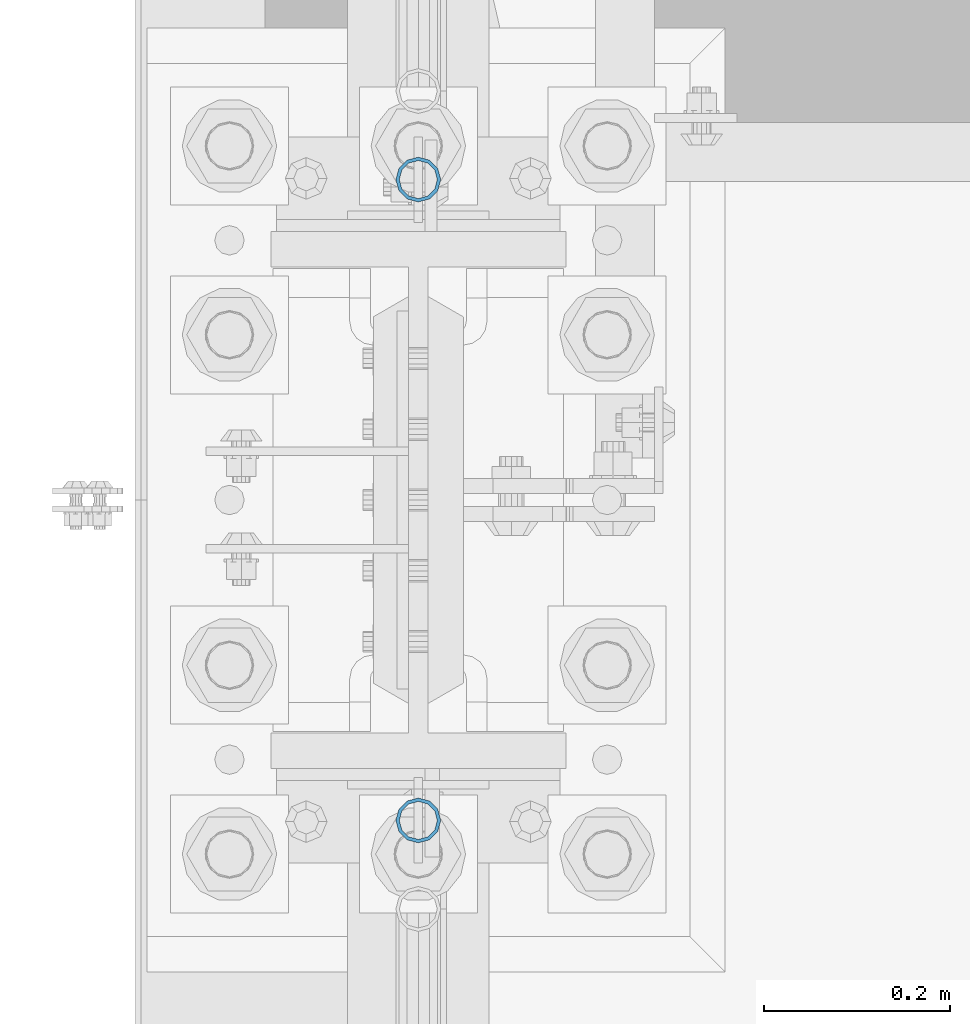
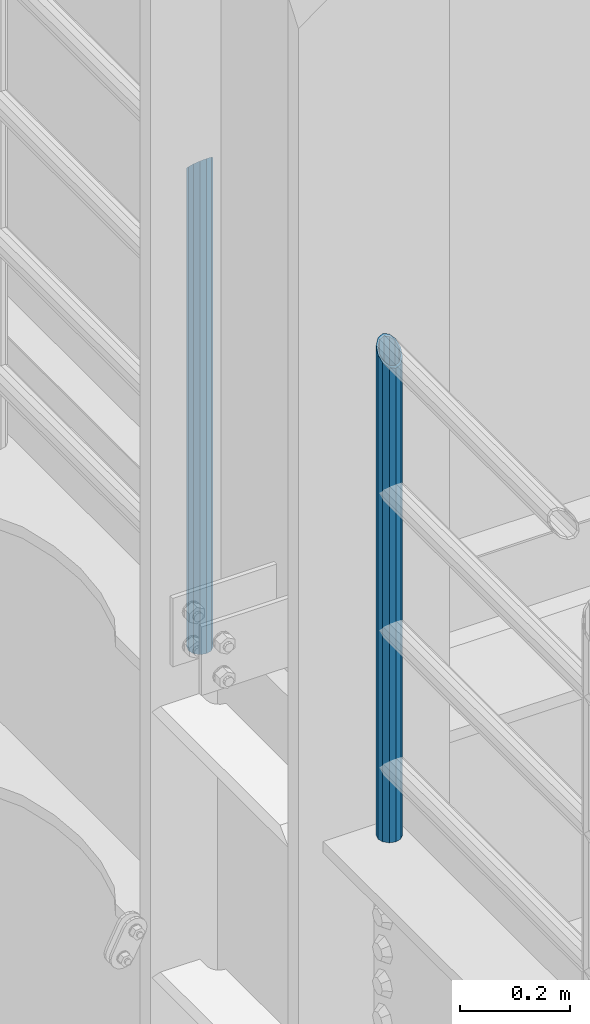
# One storey, part 685 of 1876: 2 columns, 2 elements without a shape of their own.
"""IFC2X3 building model written with IfcOpenShell, lengths in millimetres."""

import ifcopenshell
import ifcopenshell.guid

model = None  # the IFC model being written
_history = None  # IfcOwnerHistory: only IFC2X3 demands one
_inside = {}  # id of a spatial element -> (the spatial element, [elements in it])
_under = {}  # id of a project, library or spatial element -> (it, [spatial elements below it])
_declared = {}  # id of a project -> (the project, [libraries it declares])
_typed = {}  # id of a type object -> (the type object, [elements of that type])
_made_of = {}  # id of a material, layer set ... -> (it, [elements and type objects made of it])


def new_model(schema):
    """Start an empty IFC model of exactly this schema.

    Asked for "IFC4X3", IfcOpenShell would pick the latest addendum, in which some entities
    have other attributes; the version numbers below select the first issue.
    IFC2X3 requires an IfcOwnerHistory on every rooted entity: one is made here for all.
    """
    global model, _history
    if schema == "IFC4X3":
        model = ifcopenshell.file(schema_version=(4, 3, 0, 0))
    else:
        model = ifcopenshell.file(schema=schema)
    _inside.clear()
    _under.clear()
    _declared.clear()
    _typed.clear()
    _made_of.clear()
    _history = None
    if model.schema == "IFC2X3":
        org = make("IfcOrganization", Name="unknown")
        user = make(
            "IfcPersonAndOrganization",
            ThePerson=make("IfcPerson", FamilyName="unknown"),
            TheOrganization=org,
        )
        app = make(
            "IfcApplication",
            ApplicationDeveloper=org,
            Version="unknown",
            ApplicationFullName="unknown",
            ApplicationIdentifier="unknown",
        )
        _history = make(
            "IfcOwnerHistory",
            OwningUser=user,
            OwningApplication=app,
            ChangeAction="ADDED",
            CreationDate=0,
        )
    return model


def make(cls, **values):
    """One entity of the class cls with the attributes given. An attribute that is None is left unset."""
    return model.create_entity(
        cls, **{name: value for name, value in values.items() if value is not None}
    )


def rooted(cls, **values):
    """An entity with a GlobalId (a new one), such as an element, a storey or a relation."""
    return make(cls, GlobalId=ifcopenshell.guid.new(), OwnerHistory=_history, **values)


def si_unit(unit_type, name, prefix=None):
    """IfcSIUnit, for example si_unit("LENGTHUNIT", "METRE", prefix="MILLI")."""
    return make("IfcSIUnit", UnitType=unit_type, Prefix=prefix, Name=name)


def assignment(units):
    """IfcUnitAssignment: the units of a project."""
    return None if units is None else make("IfcUnitAssignment", Units=units)


def point(xyz):
    """IfcCartesianPoint."""
    return None if xyz is None else make("IfcCartesianPoint", Coordinates=xyz)


def direction(xyz):
    """IfcDirection."""
    return None if xyz is None else make("IfcDirection", DirectionRatios=xyz)


def frame(location, z_axis=None, x_axis=None):
    """IfcAxis2Placement3D, a coordinate frame: its origin and axes. An axis left out is left unset."""
    return make(
        "IfcAxis2Placement3D",
        Location=point(location),
        Axis=direction(z_axis),
        RefDirection=direction(x_axis),
    )


def origin_with_axes():
    """The frame at (0, 0, 0) with the z axis (0, 0, 1) and the x axis (1, 0, 0) written out."""
    return frame((0.0, 0.0, 0.0), z_axis=(0.0, 0.0, 1.0), x_axis=(1.0, 0.0, 0.0))


def place(relative_to, where):
    """IfcLocalPlacement: puts the frame where relative to a parent placement (None: the world)."""
    return make(
        "IfcLocalPlacement", PlacementRelTo=relative_to, RelativePlacement=where
    )


def context(
    kind, dimensions, precision=None, world=None, true_north=None, identifier=None
):
    """IfcGeometricRepresentationContext, for example the 3D "Model" context."""
    return make(
        "IfcGeometricRepresentationContext",
        ContextIdentifier=identifier,
        ContextType=kind,
        CoordinateSpaceDimension=dimensions,
        Precision=precision,
        WorldCoordinateSystem=world,
        TrueNorth=true_north,
    )


def subcontext(parent, identifier, kind, view, scale=None):
    """IfcGeometricRepresentationSubContext, for example "Body" below "Model"."""
    return make(
        "IfcGeometricRepresentationSubContext",
        ContextIdentifier=identifier,
        ContextType=kind,
        ParentContext=parent,
        TargetScale=scale,
        TargetView=view,
    )


def project(units=None, contexts=None):
    """IfcProject with its units and contexts."""
    return rooted(
        "IfcProject",
        Name="project",
        RepresentationContexts=contexts,
        UnitsInContext=assignment(units),
    )


def spatial(cls, under=None, at=None, **own):
    """A site, building, storey or space (cls), placed at a placement, below another one or the project."""
    s = rooted(cls, ObjectPlacement=at, **own)
    if under is not None:
        _under.setdefault(under.id(), (under, []))[1].append(s)
    return s


def faces_of(points, faces, orient=None, outer=None):
    """IfcFace entities. A face is a list of loops; a loop is a list of indices into points, from 0.

    orient and outer hold one flag for each loop. By default every Orientation is true, the
    first loop of a face is its IfcFaceOuterBound and the others are IfcFaceBound.
    """
    made = []
    for i, loops in enumerate(faces):
        bounds = []
        for j, loop in enumerate(loops):
            is_outer = j == 0 if outer is None else outer[i][j]
            bounds.append(
                make(
                    "IfcFaceOuterBound" if is_outer else "IfcFaceBound",
                    Bound=make("IfcPolyLoop", Polygon=[points[k] for k in loop]),
                    Orientation=True if orient is None else orient[i][j],
                )
            )
        made.append(make("IfcFace", Bounds=bounds))
    return made


def faceted_brep(points, faces, orient=None, outer=None, voids=None):
    """IfcFacetedBrep: a solid bounded by flat faces; with voids (closed shells), ...WithVoids."""
    shared = [point(p) for p in points]
    hull = make("IfcClosedShell", CfsFaces=faces_of(shared, faces, orient, outer))
    if voids is None:
        return make("IfcFacetedBrep", Outer=hull)
    return make(
        "IfcFacetedBrepWithVoids",
        Outer=hull,
        Voids=[
            make(cls, CfsFaces=faces_of(shared, fs, o, b)) for cls, fs, o, b in voids
        ],
    )


def shape(context_of_items, identifier, shape_type, items):
    """IfcShapeRepresentation: the items that make up one representation, for example the "Body"."""
    return make(
        "IfcShapeRepresentation",
        ContextOfItems=context_of_items,
        RepresentationIdentifier=identifier,
        RepresentationType=shape_type,
        Items=items,
    )


def material(Name=None, Category=None):
    """IfcMaterial."""
    return make("IfcMaterial", Name=Name, Category=Category)


def made_of(thing, what):
    """Note that an element or type object is made of a material, layer set ...; save() writes the relation."""
    if what is not None:
        _made_of.setdefault(what.id(), (what, []))[1].append(thing)
    return thing


def type_object(cls, material=None, **own):
    """A type object (cls), such as IfcWallType, which elements share."""
    return made_of(rooted(cls, **own), material)


def element(
    cls,
    number,
    at=None,
    inside=None,
    cuts=None,
    type_object=None,
    material=None,
    context=None,
    identifier="Body",
    shape_type=None,
    held_by="IfcProductDefinitionShape",
    body=None,
    shapes=None,
    **own,
):
    """One element of the class cls, such as IfcWall. Its Tag is "e" and its number.

    at: its placement. inside: the storey or other place that contains it. cuts: it is an
    opening in that element (IfcRelVoidsElement). A single representation is given by context,
    identifier, shape_type and body (its items); several are given by shapes. held_by: the class
    of the entity that holds the representations. save() writes the other relations.
    """
    e = rooted(cls, Tag="e%d" % number, ObjectPlacement=at, **own)
    if body is not None:
        shapes = [shape(context, identifier, shape_type, body)]
    if shapes is not None:
        e.Representation = make(held_by, Representations=shapes)
    if inside is not None:
        _inside.setdefault(inside.id(), (inside, []))[1].append(e)
    if cuts is not None:
        rooted(
            "IfcRelVoidsElement", RelatingBuildingElement=cuts, RelatedOpeningElement=e
        )
    if type_object is not None:
        _typed.setdefault(type_object.id(), (type_object, []))[1].append(e)
    return made_of(e, material)


def aggregate(whole, parts):
    """IfcRelAggregates: a whole, such as a stair, and the parts it consists of."""
    return rooted("IfcRelAggregates", RelatingObject=whole, RelatedObjects=parts)


def save(model, path):
    """Write the relations noted so far, then the file.

    IfcRelAggregates (storeys below a building ...), IfcRelContainedInSpatialStructure (elements
    in a storey), IfcRelDefinesByType, IfcRelAssociatesMaterial and IfcRelDeclares: one each for
    every whole, place, type object, material and project.
    """
    for whole, parts in _under.values():
        aggregate(whole, parts)
    for where, things in _inside.values():
        rooted(
            "IfcRelContainedInSpatialStructure",
            RelatedElements=things,
            RelatingStructure=where,
        )
    for kind, things in _typed.values():
        rooted("IfcRelDefinesByType", RelatedObjects=things, RelatingType=kind)
    for what, things in _made_of.values():
        rooted("IfcRelAssociatesMaterial", RelatedObjects=things, RelatingMaterial=what)
    for by, libraries in _declared.values():
        rooted("IfcRelDeclares", RelatingContext=by, RelatedDefinitions=libraries)
    model.write(path)


model = new_model("IFC2X3")

# Units and contexts
model_context = context("Model", 3, precision=1e-05, world=origin_with_axes())
body_context = subcontext(model_context, "Body", "Model", "MODEL_VIEW")
ifc_project = project(units=[si_unit("LENGTHUNIT", "METRE", prefix="MILLI"), si_unit("AREAUNIT", "SQUARE_METRE"), si_unit("VOLUMEUNIT", "CUBIC_METRE"), si_unit("MASSUNIT", "GRAM", prefix="KILO"), si_unit("TIMEUNIT", "SECOND"), si_unit("PLANEANGLEUNIT", "RADIAN"), si_unit("SOLIDANGLEUNIT", "STERADIAN"), si_unit("THERMODYNAMICTEMPERATUREUNIT", "DEGREE_CELSIUS"), si_unit("LUMINOUSINTENSITYUNIT", "LUMEN")], contexts=[model_context])

# Site, building, storey
site_placement = place(None, origin_with_axes())
site = spatial("IfcSite", under=ifc_project, at=site_placement, CompositionType="ELEMENT")
building_placement = place(site_placement, origin_with_axes())
building = spatial("IfcBuilding", under=site, at=building_placement, Name="Undefined", CompositionType="ELEMENT")
storey_placement = place(building_placement, origin_with_axes())
storey = spatial("IfcBuildingStorey", under=building, at=storey_placement, Name="Undefined", CompositionType="ELEMENT", Elevation=0.0)

# Assembly, column
assembly_1_placement = place(storey_placement, origin_with_axes())
assembly_1 = element("IfcElementAssembly", 1, at=assembly_1_placement, inside=storey, Name="RAIL", AssemblyPlace="NOTDEFINED", PredefinedType="RIGID_FRAME")
ifc_material = material()
column_type = type_object("IfcColumnType", Name="PIPE1-1/2SCH40", PredefinedType="NOTDEFINED")
column_1_placement = place(assembly_1_placement, frame((-1.81898940354586e-12, 1179.195, 8153.4), z_axis=(0.0, 1.0, 0.0), x_axis=(0.0, 0.0, 1.0)))
column_1 = element("IfcColumn", 2, at=column_1_placement, type_object=column_type, material=ifc_material, Name="POST", ObjectType="PIPE1-1/2SCH40", context=body_context, shape_type="Brep", body=[
    faceted_brep([(0.0, -20.4469999999999, 0.0), (0.0, -17.7076214311803, 10.2235000000001), (1086.54849999999, -17.7076214311801, 10.2235000000001), (1076.325, -20.4469999999999, 0.0), (0.0, -10.2235000000001, 17.7076214311801), (1094.03262143117, -10.2235000000001, 17.7076214311801), (-1.45519152283669e-11, 0.0, 20.4470000000001), (1096.77199999999, 0.0, 20.4470000000001), (0.0, 10.2235000000001, 17.7076214311801), (1094.03262143117, 10.2235000000001, 17.7076214311801), (0.0, 17.7076214311803, 10.2235000000001), (1086.54849999999, 17.7076214311801, 10.2235000000001), (0.0, 20.4469999999999, 0.0), (1076.325, 20.4469999999999, 0.0), (0.0, 17.7076214311803, -10.2235000000001), (1066.10149999999, 17.7076214311801, -10.2235000000001), (0.0, 10.2235000000001, -17.7076214311801), (1058.61737856881, 10.2235000000001, -17.7076214311801), (-1.45519152283669e-11, 0.0, -20.4470000000001), (1055.87799999999, 0.0, -20.4470000000001), (0.0, -10.2235000000001, -17.7076214311801), (1058.61737856881, -10.2235000000001, -17.7076214311801), (0.0, -17.7076214311803, -10.2235000000001), (1066.10149999999, -17.7076214311801, -10.2235000000001), (0.0, -24.1299999999992, 0.0), (0.0, -20.8971929933184, -12.0649999999996), (1064.25999999999, -20.8971929933186, -12.0649999999996), (1076.325, -24.1300000000001, 0.0), (0.0, -12.0650000000001, -20.8971929933186), (1055.42780700667, -12.0649999999996, -20.8971929933186), (-1.45519152283669e-11, 0.0, -24.130000000001), (1052.19499999999, 0.0, -24.1300000000001), (0.0, 12.0650000000001, -20.8971929933186), (1055.42780700667, 12.0649999999996, -20.8971929933186), (0.0, 20.8971929933184, -12.0649999999996), (1064.25999999999, 20.8971929933186, -12.0649999999996), (0.0, 24.1299999999992, 0.0), (1076.325, 24.1300000000001, 0.0), (0.0, 20.8971929933184, 12.0649999999996), (1088.38999999999, 20.8971929933186, 12.0649999999996), (0.0, 12.0650000000001, 20.8971929933186), (1097.22219299331, 12.0649999999996, 20.8971929933186), (-1.45519152283669e-11, 0.0, 24.130000000001), (1100.45499999999, 0.0, 24.1300000000001), (0.0, -12.0650000000001, 20.8971929933186), (1097.22219299331, -12.0649999999996, 20.8971929933186), (0.0, -20.8971929933184, 12.0649999999996), (1088.38999999999, -20.8971929933186, 12.0649999999996)], [[[0, 1, 2, 3]], [[1, 4, 5, 2]], [[4, 6, 7, 5]], [[6, 8, 9, 7]], [[8, 10, 11, 9]], [[10, 12, 13, 11]], [[12, 14, 15, 13]], [[14, 16, 17, 15]], [[16, 18, 19, 17]], [[18, 20, 21, 19]], [[20, 22, 23, 21]], [[22, 0, 3, 23]], [[24, 25, 26, 27]], [[25, 28, 29, 26]], [[28, 30, 31, 29]], [[30, 32, 33, 31]], [[32, 34, 35, 33]], [[34, 36, 37, 35]], [[36, 38, 39, 37]], [[38, 40, 41, 39]], [[40, 42, 43, 41]], [[42, 44, 45, 43]], [[44, 46, 47, 45]], [[46, 24, 27, 47]], [[29, 31, 33, 35, 37, 39, 41, 43, 45, 47, 27, 26], [5, 7, 9, 11, 13, 15, 17, 19, 21, 23, 3, 2]], [[46, 44, 42, 40, 38, 36, 34, 32, 30, 28, 25, 24], [22, 20, 18, 16, 14, 12, 10, 8, 6, 4, 1, 0]]]),
])
aggregate(assembly_1, [column_1])

assembly_2_placement = place(storey_placement, origin_with_axes())
assembly_2 = element("IfcElementAssembly", 3, at=assembly_2_placement, inside=storey, Name="RAIL", AssemblyPlace="NOTDEFINED", PredefinedType="RIGID_FRAME")
column_2_placement = place(assembly_2_placement, frame((-1.81898940354586e-12, 1868.805, 8153.4), z_axis=(0.0, 1.0, 0.0), x_axis=(0.0, 0.0, 1.0)))
column_2 = element("IfcColumn", 4, at=column_2_placement, type_object=column_type, material=ifc_material, Name="POST", ObjectType="PIPE1-1/2SCH40", context=body_context, shape_type="Brep", body=[
    faceted_brep([(0.0, -20.4469999999999, 0.0), (0.0, -17.7076214311803, 10.2235000000001), (1066.1015, -17.7076214311803, 10.2235000000001), (1076.325, -20.4469999999999, 0.0), (0.0, -10.2235000000001, 17.7076214311801), (1058.61737856882, -10.2235000000001, 17.7076214311801), (-1.45519152283669e-11, 0.0, 20.4470000000001), (1055.878, 0.0, 20.4470000000001), (0.0, 10.2235000000001, 17.7076214311801), (1058.61737856882, 10.2235000000001, 17.7076214311801), (0.0, 17.7076214311803, 10.2235000000001), (1066.1015, 17.7076214311803, 10.2235000000001), (0.0, 20.4469999999999, 0.0), (1076.325, 20.4469999999999, 0.0), (0.0, 17.7076214311803, -10.2235000000001), (1086.5485, 17.7076214311803, -10.2235000000001), (0.0, 10.2235000000001, -17.7076214311801), (1094.03262143118, 10.2235000000001, -17.7076214311801), (-1.45519152283669e-11, 0.0, -20.4470000000001), (1096.772, 0.0, -20.4470000000001), (0.0, -10.2235000000001, -17.7076214311801), (1094.03262143118, -10.2235000000001, -17.7076214311801), (0.0, -17.7076214311803, -10.2235000000001), (1086.5485, -17.7076214311803, -10.2235000000001), (0.0, -24.1299999999992, 0.0), (0.0, -20.8971929933184, -12.0649999999996), (1088.39, -20.8971929933184, -12.0649999999996), (1076.325, -24.1300000000001, 0.0), (0.0, -12.0650000000001, -20.8971929933186), (1097.22219299332, -12.0650000000001, -20.8971929933186), (-1.45519152283669e-11, 0.0, -24.130000000001), (1100.455, 0.0, -24.1300000000001), (0.0, 12.0650000000001, -20.8971929933186), (1097.22219299332, 12.0650000000001, -20.8971929933186), (0.0, 20.8971929933184, -12.0649999999996), (1088.39, 20.8971929933184, -12.0649999999996), (0.0, 24.1299999999992, 0.0), (1076.325, 24.1300000000001, 0.0), (0.0, 20.8971929933184, 12.0649999999996), (1064.26, 20.8971929933184, 12.0649999999996), (0.0, 12.0650000000001, 20.8971929933186), (1055.42780700668, 12.0650000000001, 20.8971929933186), (-1.45519152283669e-11, 0.0, 24.130000000001), (1052.195, 0.0, 24.1300000000001), (0.0, -12.0650000000001, 20.8971929933186), (1055.42780700668, -12.0650000000001, 20.8971929933186), (0.0, -20.8971929933184, 12.0649999999996), (1064.26, -20.8971929933184, 12.0649999999996)], [[[0, 1, 2, 3]], [[1, 4, 5, 2]], [[4, 6, 7, 5]], [[6, 8, 9, 7]], [[8, 10, 11, 9]], [[10, 12, 13, 11]], [[12, 14, 15, 13]], [[14, 16, 17, 15]], [[16, 18, 19, 17]], [[18, 20, 21, 19]], [[20, 22, 23, 21]], [[22, 0, 3, 23]], [[24, 25, 26, 27]], [[25, 28, 29, 26]], [[28, 30, 31, 29]], [[30, 32, 33, 31]], [[32, 34, 35, 33]], [[34, 36, 37, 35]], [[36, 38, 39, 37]], [[38, 40, 41, 39]], [[40, 42, 43, 41]], [[42, 44, 45, 43]], [[44, 46, 47, 45]], [[46, 24, 27, 47]], [[29, 31, 33, 35, 37, 39, 41, 43, 45, 47, 27, 26], [5, 7, 9, 11, 13, 15, 17, 19, 21, 23, 3, 2]], [[46, 44, 42, 40, 38, 36, 34, 32, 30, 28, 25, 24], [22, 20, 18, 16, 14, 12, 10, 8, 6, 4, 1, 0]]]),
])
aggregate(assembly_2, [column_2])

save(model, "model.ifc")
